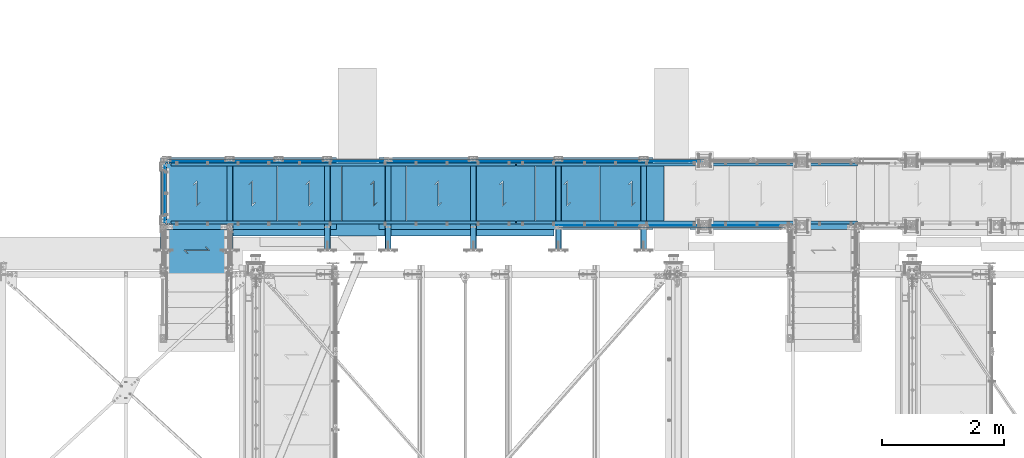
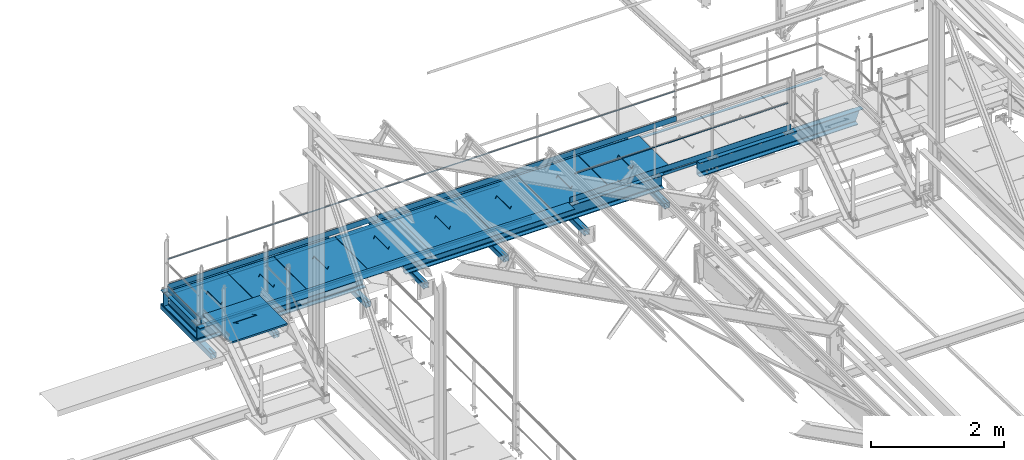
# One storey, part 52 of 496: 34 beams, 32 elements without a shape of their own.
"""IFC2X3 building model written with IfcOpenShell, lengths in millimetres."""

from ifc_helpers import new_model, si_unit, frame, origin_with_axes, origin_2d_with_axis, place, context, subcontext, project, spatial, polyline, rectangle, hollow_rectangle, hollow_circle, l_section, u_section, outline, extrude, boolean, clip, halfspace, material, type_object, element, aggregate, save


model = new_model("IFC2X3")

# Units and contexts
model_context = context("Model", 3, precision=1e-05, world=origin_with_axes())
body_context = subcontext(model_context, "Body", "Model", "MODEL_VIEW")
ifc_project = project(units=[si_unit("LENGTHUNIT", "METRE", prefix="MILLI"), si_unit("AREAUNIT", "SQUARE_METRE"), si_unit("VOLUMEUNIT", "CUBIC_METRE"), si_unit("MASSUNIT", "GRAM", prefix="KILO"), si_unit("TIMEUNIT", "SECOND"), si_unit("PLANEANGLEUNIT", "RADIAN"), si_unit("SOLIDANGLEUNIT", "STERADIAN"), si_unit("THERMODYNAMICTEMPERATUREUNIT", "DEGREE_CELSIUS"), si_unit("LUMINOUSINTENSITYUNIT", "LUMEN")], contexts=[model_context])

# Site, building, storey
site_placement = place(None, origin_with_axes())
site = spatial("IfcSite", under=ifc_project, at=site_placement, CompositionType="ELEMENT")
building_placement = place(site_placement, origin_with_axes())
building = spatial("IfcBuilding", under=site, at=building_placement, Name="Undefined", CompositionType="ELEMENT")
storey_placement = place(building_placement, origin_with_axes())
storey = spatial("IfcBuildingStorey", under=building, at=storey_placement, Name="Undefined", CompositionType="ELEMENT", Elevation=0.0)

# Assembly, beam
assembly_1_placement = place(storey_placement, origin_with_axes())
assembly_1 = element("IfcElementAssembly", 1, at=assembly_1_placement, inside=storey, Name="MAIN COURANTE", AssemblyPlace="NOTDEFINED", PredefinedType="NOTDEFINED")
ifc_material_1 = material(Name="Undefined/S235-E24")
beam_type_1 = type_object("IfcBeamType", PredefinedType="NOTDEFINED")
beam_1_placement = place(assembly_1_placement, frame((17579.9961849193, 15930.0010285632, 8703.00000001012), z_axis=(0.0, -1.0, 0.0), x_axis=(-1.0, 0.0, 0.0)))
beam_1 = element("IfcBeam", 2, at=beam_1_placement, type_object=beam_type_1, material=ifc_material_1, Name="VIDE", context=body_context, shape_type="SweptSolid", body=[
    extrude(rectangle(XDim=6.0, YDim=200.0, at=origin_2d_with_axis()), frame((5350.00080258181, 0.0, 0.0), z_axis=(-1.0, 0.0, 0.0), x_axis=(0.0, -1.0, 0.0)), (0.0, 0.0, 1.0), 5350.0),
])
aggregate(assembly_1, [beam_1])

assembly_2_placement = place(storey_placement, origin_with_axes())
assembly_2 = element("IfcElementAssembly", 3, at=assembly_2_placement, inside=storey, Name="MAIN COURANTE", AssemblyPlace="NOTDEFINED", PredefinedType="NOTDEFINED")
beam_type_2 = type_object("IfcBeamType", PredefinedType="NOTDEFINED")
beam_2_placement = place(assembly_2_placement, frame((17659.9961849193, 15969.9996218665, 9243.80000001012), z_axis=(0.0, -1.0, 0.0), x_axis=(1.0, 0.0, 0.0)))
beam_2 = element("IfcBeam", 4, at=beam_2_placement, type_object=beam_type_2, material=ifc_material_1, Name="LISSE", context=body_context, shape_type="SweptSolid", body=[
    extrude(hollow_circle(Radius=10.64999962, WallThickness=2.0, at=origin_2d_with_axis()), frame((3709.98893280412, 0.0, -4.91012946880298e-20), z_axis=(-1.0, 0.0, 0.0), x_axis=(0.0, -1.0, 0.0)), (0.0, 0.0, 1.0), 3709.99),
])
aggregate(assembly_2, [beam_2])

assembly_3_placement = place(storey_placement, origin_with_axes())
assembly_3 = element("IfcElementAssembly", 5, at=assembly_3_placement, inside=storey, Name="MAIN COURANTE", AssemblyPlace="NOTDEFINED", PredefinedType="NOTDEFINED")
beam_3_placement = place(assembly_3_placement, frame((14859.9961849193, 17089.994110687, 9243.80000001012), z_axis=(0.0, 1.0, 0.0), x_axis=(1.0, 0.0, 0.0)))
beam_3 = element("IfcBeam", 6, at=beam_3_placement, type_object=beam_type_2, material=ifc_material_1, Name="LISSE", context=body_context, shape_type="SweptSolid", body=[
    extrude(hollow_circle(Radius=10.64999962, WallThickness=2.0, at=origin_2d_with_axis()), frame((5189.99999999648, 0.0, 0.0), z_axis=(-1.0, 0.0, 0.0), x_axis=(0.0, -1.0, 0.0)), (0.0, 0.0, 1.0), 5190.0),
])

assembly_4_placement = place(storey_placement, origin_with_axes())
assembly_4 = element("IfcElementAssembly", 7, at=assembly_4_placement, inside=storey, Name="MAIN COURANTE", AssemblyPlace="NOTDEFINED", PredefinedType="NOTDEFINED")
beam_4_placement = place(assembly_4_placement, frame((11225.0062475613, 17089.9937511109, 9243.80000001012), z_axis=(0.0, 1.0, 0.0), x_axis=(1.0, 0.0, 0.0)))
beam_4 = element("IfcBeam", 8, at=beam_4_placement, type_object=beam_type_2, material=ifc_material_1, Name="LISSE", context=body_context, shape_type="SweptSolid", body=[
    extrude(hollow_circle(Radius=10.64999962, WallThickness=2.0, at=origin_2d_with_axis()), frame((3624.98993735802, 0.0, 0.0), z_axis=(-1.0, 0.0, 0.0), x_axis=(0.0, -1.0, 0.0)), (0.0, 0.0, 1.0), 3624.99),
])

assembly_5_placement = place(storey_placement, origin_with_axes())
assembly_5 = element("IfcElementAssembly", 9, at=assembly_5_placement, inside=storey, Name="CONSOLE", AssemblyPlace="NOTDEFINED", PredefinedType="NOTDEFINED")
beam_type_3 = type_object("IfcBeamType", PredefinedType="NOTDEFINED")
beam_5_placement = place(assembly_5_placement, frame((12255.0007605158, 17119.9934272352, 8390.0), z_axis=(-1.0, 0.0, 0.0), x_axis=(0.0, -1.0, 0.0)))
beam_5 = element("IfcBeam", 10, at=beam_5_placement, type_object=beam_type_3, material=ifc_material_1, Name="CONSOLE", context=body_context, shape_type="CSG", body=[
    boolean("DIFFERENCE", extrude(hollow_rectangle(XDim=100.0, YDim=100.0, WallThickness=5.0, InnerFilletRadius=5.0, OuterFilletRadius=10.0, at=origin_2d_with_axis()), frame((1517.99358081521, 0.0, 0.0), z_axis=(-1.0, 0.0, 0.0), x_axis=(0.0, -1.0, 0.0)), (0.0, 0.0, 1.0), 1517.99), extrude(outline(polyline([(0.0, 0.0), (20.0, 0.0), (20.0, 300.0), (0.0, 300.0), (-118.0, 275.0), (-118.0, 155.0), (0.0, 0.0)])), frame((1497.99342723521, -215.0, -4.0), z_axis=(0.0, 0.0, 1.0), x_axis=(1.0, 0.0, 0.0)), (0.0, 0.0, 1.0), 8.0)),
])
aggregate(assembly_5, [beam_5])

assembly_6_placement = place(storey_placement, origin_with_axes())
assembly_6 = element("IfcElementAssembly", 11, at=assembly_6_placement, inside=storey, Name="CONSOLE", AssemblyPlace="NOTDEFINED", PredefinedType="NOTDEFINED")
beam_6_placement = place(assembly_6_placement, frame((19055.0007605158, 17119.9934272352, 8390.0), z_axis=(-1.0, 0.0, 0.0), x_axis=(0.0, -1.0, 0.0)))
beam_6 = element("IfcBeam", 12, at=beam_6_placement, type_object=beam_type_3, material=ifc_material_1, Name="CONSOLE", context=body_context, shape_type="CSG", body=[
    boolean("DIFFERENCE", extrude(hollow_rectangle(XDim=100.0, YDim=100.0, WallThickness=5.0, InnerFilletRadius=5.0, OuterFilletRadius=10.0, at=origin_2d_with_axis()), frame((1517.99358081521, 0.0, 0.0), z_axis=(-1.0, 0.0, 0.0), x_axis=(0.0, -1.0, 0.0)), (0.0, 0.0, 1.0), 1517.99), extrude(outline(polyline([(0.0, 0.0), (20.0, 0.0), (20.0, 300.0), (0.0, 300.0), (-118.0, 275.0), (-118.0, 155.0), (0.0, 0.0)])), frame((1497.99342723521, -215.0, -4.0), z_axis=(0.0, 0.0, 1.0), x_axis=(1.0, 0.0, 0.0)), (0.0, 0.0, 1.0), 8.0)),
])
aggregate(assembly_6, [beam_6])

assembly_7_placement = place(storey_placement, origin_with_axes())
assembly_7 = element("IfcElementAssembly", 13, at=assembly_7_placement, inside=storey, Name="CONSOLE", AssemblyPlace="NOTDEFINED", PredefinedType="NOTDEFINED")
beam_7_placement = place(assembly_7_placement, frame((17655.0007605158, 17119.9934272352, 8390.0), z_axis=(-1.0, 0.0, 0.0), x_axis=(0.0, -1.0, 0.0)))
beam_7 = element("IfcBeam", 14, at=beam_7_placement, type_object=beam_type_3, material=ifc_material_1, Name="CONSOLE", context=body_context, shape_type="CSG", body=[
    boolean("DIFFERENCE", extrude(hollow_rectangle(XDim=100.0, YDim=100.0, WallThickness=5.0, InnerFilletRadius=5.0, OuterFilletRadius=10.0, at=origin_2d_with_axis()), frame((1517.99358081521, 0.0, 0.0), z_axis=(-1.0, 0.0, 0.0), x_axis=(0.0, -1.0, 0.0)), (0.0, 0.0, 1.0), 1517.99), extrude(outline(polyline([(0.0, 0.0), (20.0, 0.0), (20.0, 300.0), (0.0, 300.0), (-118.0, 275.0), (-118.0, 155.0), (0.0, 0.0)])), frame((1497.99342723521, -215.0, -4.0), z_axis=(0.0, 0.0, 1.0), x_axis=(1.0, 0.0, 0.0)), (0.0, 0.0, 1.0), 8.0)),
])
aggregate(assembly_7, [beam_7])

assembly_8_placement = place(storey_placement, origin_with_axes())
assembly_8 = element("IfcElementAssembly", 15, at=assembly_8_placement, inside=storey, Name="CONSOLE", AssemblyPlace="NOTDEFINED", PredefinedType="NOTDEFINED")
beam_8_placement = place(assembly_8_placement, frame((16255.0007605158, 17119.9934272352, 8390.0), z_axis=(-1.0, 0.0, 0.0), x_axis=(0.0, -1.0, 0.0)))
beam_8 = element("IfcBeam", 16, at=beam_8_placement, type_object=beam_type_3, material=ifc_material_1, Name="CONSOLE", context=body_context, shape_type="CSG", body=[
    boolean("DIFFERENCE", extrude(hollow_rectangle(XDim=100.0, YDim=100.0, WallThickness=5.0, InnerFilletRadius=5.0, OuterFilletRadius=10.0, at=origin_2d_with_axis()), frame((1517.99358081521, 0.0, 0.0), z_axis=(-1.0, 0.0, 0.0), x_axis=(0.0, -1.0, 0.0)), (0.0, 0.0, 1.0), 1517.99), extrude(outline(polyline([(0.0, 0.0), (20.0, 0.0), (20.0, 300.0), (0.0, 300.0), (-118.0, 275.0), (-118.0, 155.0), (0.0, 0.0)])), frame((1497.99342723521, -215.0, -4.0), z_axis=(0.0, 0.0, 1.0), x_axis=(1.0, 0.0, 0.0)), (0.0, 0.0, 1.0), 8.0)),
])
aggregate(assembly_8, [beam_8])

assembly_9_placement = place(storey_placement, origin_with_axes())
assembly_9 = element("IfcElementAssembly", 17, at=assembly_9_placement, inside=storey, Name="CONSOLE", AssemblyPlace="NOTDEFINED", PredefinedType="NOTDEFINED")
beam_9_placement = place(assembly_9_placement, frame((14855.0007605158, 17119.9934272352, 8390.0), z_axis=(-1.0, 0.0, 0.0), x_axis=(0.0, -1.0, 0.0)))
beam_9 = element("IfcBeam", 18, at=beam_9_placement, type_object=beam_type_3, material=ifc_material_1, Name="CONSOLE", context=body_context, shape_type="CSG", body=[
    boolean("DIFFERENCE", extrude(hollow_rectangle(XDim=100.0, YDim=100.0, WallThickness=5.0, InnerFilletRadius=5.0, OuterFilletRadius=10.0, at=origin_2d_with_axis()), frame((1517.99358081521, 0.0, 0.0), z_axis=(-1.0, 0.0, 0.0), x_axis=(0.0, -1.0, 0.0)), (0.0, 0.0, 1.0), 1517.99), extrude(outline(polyline([(0.0, 0.0), (20.0, 0.0), (20.0, 300.0), (0.0, 300.0), (-118.0, 275.0), (-118.0, 155.0), (0.0, 0.0)])), frame((1497.99342723521, -215.0, -4.0), z_axis=(0.0, 0.0, 1.0), x_axis=(1.0, 0.0, 0.0)), (0.0, 0.0, 1.0), 8.0)),
])
aggregate(assembly_9, [beam_9])

assembly_10_placement = place(storey_placement, origin_with_axes())
assembly_10 = element("IfcElementAssembly", 19, at=assembly_10_placement, inside=storey, Name="CONSOLE", AssemblyPlace="NOTDEFINED", PredefinedType="NOTDEFINED")
beam_10_placement = place(assembly_10_placement, frame((13855.0007605158, 17119.9934272352, 8390.0), z_axis=(-1.0, 0.0, 0.0), x_axis=(0.0, -1.0, 0.0)))
beam_10 = element("IfcBeam", 20, at=beam_10_placement, type_object=beam_type_3, material=ifc_material_1, Name="CONSOLE", context=body_context, shape_type="CSG", body=[
    boolean("DIFFERENCE", extrude(hollow_rectangle(XDim=100.0, YDim=100.0, WallThickness=5.0, InnerFilletRadius=5.0, OuterFilletRadius=10.0, at=origin_2d_with_axis()), frame((1517.99358081521, 0.0, 0.0), z_axis=(-1.0, 0.0, 0.0), x_axis=(0.0, -1.0, 0.0)), (0.0, 0.0, 1.0), 1517.99), extrude(outline(polyline([(0.0, 0.0), (20.0, 0.0), (20.0, 300.0), (0.0, 300.0), (-118.0, 275.0), (-118.0, 155.0), (0.0, 0.0)])), frame((1497.99342723521, -215.0, -4.0), z_axis=(0.0, 0.0, 1.0), x_axis=(1.0, 0.0, 0.0)), (0.0, 0.0, 1.0), 8.0)),
])
aggregate(assembly_10, [beam_10])

assembly_11_placement = place(storey_placement, origin_with_axes())
assembly_11 = element("IfcElementAssembly", 21, at=assembly_11_placement, inside=storey, Name="CONSOLE", AssemblyPlace="NOTDEFINED", PredefinedType="NOTDEFINED")
beam_11_placement = place(assembly_11_placement, frame((11165.0007605157, 17119.9935808152, 8390.0), z_axis=(-1.0, 0.0, 0.0), x_axis=(0.0, -1.0, 0.0)))
beam_11 = element("IfcBeam", 22, at=beam_11_placement, type_object=beam_type_3, material=ifc_material_1, Name="CONSOLE", context=body_context, shape_type="CSG", body=[
    boolean("DIFFERENCE", extrude(hollow_rectangle(XDim=100.0, YDim=100.0, WallThickness=5.0, InnerFilletRadius=5.0, OuterFilletRadius=10.0, at=origin_2d_with_axis()), frame((1517.99358081521, 0.0, 0.0), z_axis=(-1.0, 0.0, 0.0), x_axis=(0.0, -1.0, 0.0)), (0.0, 0.0, 1.0), 1517.99), extrude(outline(polyline([(0.0, 0.0), (20.0, 0.0), (20.0, 300.0), (0.0, 300.0), (-118.0, 275.0), (-118.0, 155.0), (0.0, 0.0)])), frame((1497.99358081521, -215.0, -4.0), z_axis=(0.0, 0.0, 1.0), x_axis=(1.0, 0.0, 0.0)), (0.0, 0.0, 1.0), 8.0)),
])
aggregate(assembly_11, [beam_11])

assembly_12_placement = place(storey_placement, origin_with_axes())
assembly_12 = element("IfcElementAssembly", 23, at=assembly_12_placement, inside=storey, AssemblyPlace="NOTDEFINED", PredefinedType="NOTDEFINED")
beam_type_4 = type_object("IfcBeamType", PredefinedType="NOTDEFINED")
beam_12_placement = place(assembly_12_placement, frame((21439.9851177268, 16002.5124739778, 8760.00000001012), z_axis=(0.0, 0.0, -1.0), x_axis=(-1.0, 0.0, 0.0)))
beam_12 = element("IfcBeam", 24, at=beam_12_placement, type_object=beam_type_4, material=ifc_material_1, context=body_context, shape_type="SweptSolid", body=[
    extrude(rectangle(XDim=5.0, YDim=100.0, at=origin_2d_with_axis()), frame((3849.98893280756, 0.0, 0.0), z_axis=(-1.0, 0.0, 0.0), x_axis=(0.0, -1.0, 0.0)), (0.0, 0.0, 1.0), 3849.99),
])
aggregate(assembly_12, [beam_12])

# Beam
beam_13_placement = place(assembly_3_placement, frame((20054.9961849193, 17057.481480291, 8760.00000001012), z_axis=(0.0, 0.0, -1.0), x_axis=(-1.0, 0.0, 0.0)))
beam_13 = element("IfcBeam", 25, at=beam_13_placement, type_object=beam_type_4, material=ifc_material_1, context=body_context, shape_type="SweptSolid", body=[
    extrude(rectangle(XDim=5.0, YDim=100.0, at=origin_2d_with_axis()), frame((5200.0, 0.0, 0.0), z_axis=(-1.0, 0.0, 0.0), x_axis=(0.0, -1.0, 0.0)), (0.0, 0.0, 1.0), 5200.0),
])

aggregate(assembly_3, [beam_13, beam_3])

beam_14_placement = place(assembly_4_placement, frame((14854.9961849193, 17057.481480291, 8760.00000001012), z_axis=(0.0, 0.0, -1.0), x_axis=(-1.0, 0.0, 0.0)))
beam_14 = element("IfcBeam", 26, at=beam_14_placement, type_object=beam_type_4, material=ifc_material_1, context=body_context, shape_type="SweptSolid", body=[
    extrude(rectangle(XDim=5.0, YDim=100.0, at=origin_2d_with_axis()), frame((3649.98401228106, 0.0, 0.0), z_axis=(-1.0, 0.0, 0.0), x_axis=(0.0, -1.0, 0.0)), (0.0, 0.0, 1.0), 3649.98),
])

aggregate(assembly_4, [beam_14, beam_4])

# Assembly, beam
assembly_13_placement = place(storey_placement, origin_with_axes())
assembly_13 = element("IfcElementAssembly", 27, at=assembly_13_placement, inside=storey, Name="MAIN COURANTE", AssemblyPlace="NOTDEFINED", PredefinedType="NOTDEFINED")
beam_15_placement = place(assembly_13_placement, frame((11182.4987221813, 17034.9977309424, 8760.00000001012), z_axis=(0.0, 0.0, -1.0), x_axis=(0.0, -1.0, 0.0)))
beam_15 = element("IfcBeam", 28, at=beam_15_placement, type_object=beam_type_4, material=ifc_material_1, context=body_context, shape_type="SweptSolid", body=[
    extrude(rectangle(XDim=5.0, YDim=100.0, at=origin_2d_with_axis()), frame((1009.99407492107, 0.0, 0.0), z_axis=(-1.0, 0.0, 0.0), x_axis=(0.0, -1.0, 0.0)), (0.0, 0.0, 1.0), 1009.99),
])
aggregate(assembly_13, [beam_15])

assembly_14_placement = place(storey_placement, origin_with_axes())
assembly_14 = element("IfcElementAssembly", 29, at=assembly_14_placement, inside=storey, Name="PALIER", AssemblyPlace="NOTDEFINED", PredefinedType="NOTDEFINED")
beam_type_5 = type_object("IfcBeamType", PredefinedType="NOTDEFINED")
beam_16_placement = place(assembly_14_placement, frame((13024.9999902344, 16530.001494552, 8685.0), z_axis=(0.0, 1.0, 0.0), x_axis=(-1.0, 0.0, 0.0)))
beam_16 = element("IfcBeam", 30, at=beam_16_placement, type_object=beam_type_5, material=ifc_material_1, Name="PALIER", context=body_context, shape_type="CSG", body=[
    boolean("DIFFERENCE", extrude(rectangle(XDim=30.0, YDim=990.0, at=origin_2d_with_axis()), frame((810.0, 0.0, 0.0), z_axis=(-1.0, 0.0, 0.0), x_axis=(0.0, -1.0, 0.0)), (0.0, 0.0, 1.0), 810.0), extrude(outline(polyline([(0.0, 0.0), (87.0678024292865, -7.27595761418343e-12), (-195.774902343946, 282.842712402629), (-132.842712402475, 282.842712402631), (-132.842712402482, 292.84271240264), (-219.917037964085, 292.84271240264), (62.9256706238448, 10.0000000000091), (-1.81898940354586e-10, 10.0000000000073), (0.0, 0.0)])), frame((348.432567747415, 17.4998126435639, -150.504333634472), z_axis=(0.0, -1.0, 0.0), x_axis=(0.707106781186548, 0.0, -0.707106781186548)), (0.0, 0.0, 1.0), 35.0)),
])
aggregate(assembly_14, [beam_16])

assembly_15_placement = place(storey_placement, origin_with_axes())
assembly_15 = element("IfcElementAssembly", 31, at=assembly_15_placement, inside=storey, Name="PALIER", AssemblyPlace="NOTDEFINED", PredefinedType="NOTDEFINED")
beam_17_placement = place(assembly_15_placement, frame((14084.9999902344, 16530.001494552, 8685.0), z_axis=(0.0, 1.0, 0.0), x_axis=(-1.0, 0.0, 0.0)))
beam_17 = element("IfcBeam", 32, at=beam_17_placement, type_object=beam_type_5, material=ifc_material_1, Name="PALIER", context=body_context, shape_type="CSG", body=[
    boolean("DIFFERENCE", extrude(rectangle(XDim=30.0, YDim=990.0, at=origin_2d_with_axis()), frame((1050.0, 0.0, 0.0), z_axis=(-1.0, 0.0, 0.0), x_axis=(0.0, -1.0, 0.0)), (0.0, 0.0, 1.0), 1050.0), extrude(outline(polyline([(0.0, 0.0), (87.0678024292865, -7.27595761418343e-12), (-195.774902343946, 282.842712402629), (-132.842712402475, 282.842712402631), (-132.842712402482, 292.84271240264), (-219.917037964085, 292.84271240264), (62.9256706238448, 10.0000000000091), (-1.81898940354586e-10, 10.0000000000073), (0.0, 0.0)])), frame((468.433762432338, 17.4998126435639, -150.504333634472), z_axis=(0.0, -1.0, 0.0), x_axis=(0.707106781186548, 0.0, -0.707106781186548)), (0.0, 0.0, 1.0), 35.0)),
])
aggregate(assembly_15, [beam_17])

assembly_16_placement = place(storey_placement, origin_with_axes())
assembly_16 = element("IfcElementAssembly", 33, at=assembly_16_placement, inside=storey, Name="PALIER", AssemblyPlace="NOTDEFINED", PredefinedType="NOTDEFINED")
beam_18_placement = place(assembly_16_placement, frame((15144.9999902344, 16530.001494552, 8685.0), z_axis=(0.0, 1.0, 0.0), x_axis=(-1.0, 0.0, 0.0)))
beam_18 = element("IfcBeam", 34, at=beam_18_placement, type_object=beam_type_5, material=ifc_material_1, Name="PALIER", context=body_context, shape_type="CSG", body=[
    boolean("DIFFERENCE", extrude(rectangle(XDim=30.0, YDim=990.0, at=origin_2d_with_axis()), frame((1050.0, 0.0, 0.0), z_axis=(-1.0, 0.0, 0.0), x_axis=(0.0, -1.0, 0.0)), (0.0, 0.0, 1.0), 1050.0), extrude(outline(polyline([(0.0, 0.0), (87.0678024292865, -7.27595761418343e-12), (-195.774902343946, 282.842712402629), (-132.842712402475, 282.842712402631), (-132.842712402482, 292.84271240264), (-219.917037964085, 292.84271240264), (62.9256706238448, 10.0000000000091), (-1.81898940354586e-10, 10.0000000000073), (0.0, 0.0)])), frame((468.433762432338, 17.4998126435639, -150.504333634472), z_axis=(0.0, -1.0, 0.0), x_axis=(0.707106781186548, 0.0, -0.707106781186548)), (0.0, 0.0, 1.0), 35.0)),
])
aggregate(assembly_16, [beam_18])

assembly_17_placement = place(storey_placement, origin_with_axes())
assembly_17 = element("IfcElementAssembly", 35, at=assembly_17_placement, inside=storey, Name="PALIER", AssemblyPlace="NOTDEFINED", PredefinedType="NOTDEFINED")
beam_19_placement = place(assembly_17_placement, frame((16204.9999902344, 16530.001494552, 8685.0), z_axis=(0.0, 1.0, 0.0), x_axis=(-1.0, 0.0, 0.0)))
beam_19 = element("IfcBeam", 36, at=beam_19_placement, type_object=beam_type_5, material=ifc_material_1, Name="PALIER", context=body_context, shape_type="CSG", body=[
    boolean("DIFFERENCE", extrude(rectangle(XDim=30.0, YDim=990.0, at=origin_2d_with_axis()), frame((1050.0, 0.0, 0.0), z_axis=(-1.0, 0.0, 0.0), x_axis=(0.0, -1.0, 0.0)), (0.0, 0.0, 1.0), 1050.0), extrude(outline(polyline([(0.0, 0.0), (87.0678024292865, -7.27595761418343e-12), (-195.774902343946, 282.842712402629), (-132.842712402475, 282.842712402631), (-132.842712402482, 292.84271240264), (-219.917037964085, 292.84271240264), (62.9256706238448, 10.0000000000091), (-1.81898940354586e-10, 10.0000000000073), (0.0, 0.0)])), frame((468.433762432338, 17.4998126435639, -150.504333634472), z_axis=(0.0, -1.0, 0.0), x_axis=(0.707106781186548, 0.0, -0.707106781186548)), (0.0, 0.0, 1.0), 35.0)),
])
aggregate(assembly_17, [beam_19])

assembly_18_placement = place(storey_placement, origin_with_axes())
assembly_18 = element("IfcElementAssembly", 37, at=assembly_18_placement, inside=storey, Name="PALIER", AssemblyPlace="NOTDEFINED", PredefinedType="NOTDEFINED")
beam_20_placement = place(assembly_18_placement, frame((17264.9999902344, 16530.001494552, 8685.0), z_axis=(0.0, 1.0, 0.0), x_axis=(-1.0, 0.0, 0.0)))
beam_20 = element("IfcBeam", 38, at=beam_20_placement, type_object=beam_type_5, material=ifc_material_1, Name="PALIER", context=body_context, shape_type="CSG", body=[
    boolean("DIFFERENCE", extrude(rectangle(XDim=30.0, YDim=990.0, at=origin_2d_with_axis()), frame((1050.0, 0.0, 0.0), z_axis=(-1.0, 0.0, 0.0), x_axis=(0.0, -1.0, 0.0)), (0.0, 0.0, 1.0), 1050.0), extrude(outline(polyline([(0.0, 0.0), (87.0678024292865, -7.27595761418343e-12), (-195.774902343946, 282.842712402629), (-132.842712402475, 282.842712402631), (-132.842712402482, 292.84271240264), (-219.917037964085, 292.84271240264), (62.9256706238448, 10.0000000000091), (-1.81898940354586e-10, 10.0000000000073), (0.0, 0.0)])), frame((468.432567747415, 17.4998126435639, -150.504333634472), z_axis=(0.0, -1.0, 0.0), x_axis=(0.707106781186548, 0.0, -0.707106781186548)), (0.0, 0.0, 1.0), 35.0)),
])
aggregate(assembly_18, [beam_20])

assembly_19_placement = place(storey_placement, origin_with_axes())
assembly_19 = element("IfcElementAssembly", 39, at=assembly_19_placement, inside=storey, Name="PALIER", AssemblyPlace="NOTDEFINED", PredefinedType="NOTDEFINED")
beam_21_placement = place(assembly_19_placement, frame((18324.9999902344, 16530.001494552, 8685.0), z_axis=(0.0, 1.0, 0.0), x_axis=(-1.0, 0.0, 0.0)))
beam_21 = element("IfcBeam", 40, at=beam_21_placement, type_object=beam_type_5, material=ifc_material_1, Name="PALIER", context=body_context, shape_type="CSG", body=[
    boolean("DIFFERENCE", extrude(rectangle(XDim=30.0, YDim=990.0, at=origin_2d_with_axis()), frame((1050.0, 0.0, 0.0), z_axis=(-1.0, 0.0, 0.0), x_axis=(0.0, -1.0, 0.0)), (0.0, 0.0, 1.0), 1050.0), extrude(outline(polyline([(0.0, 0.0), (87.0678024292865, -7.27595761418343e-12), (-195.774902343946, 282.842712402629), (-132.842712402475, 282.842712402631), (-132.842712402482, 292.84271240264), (-219.917037964085, 292.84271240264), (62.9256706238448, 10.0000000000091), (-1.81898940354586e-10, 10.0000000000073), (0.0, 0.0)])), frame((468.433762432338, 17.4998126435639, -150.504333634472), z_axis=(0.0, -1.0, 0.0), x_axis=(0.707106781186548, 0.0, -0.707106781186548)), (0.0, 0.0, 1.0), 35.0)),
])
aggregate(assembly_19, [beam_21])

assembly_20_placement = place(storey_placement, origin_with_axes())
assembly_20 = element("IfcElementAssembly", 41, at=assembly_20_placement, inside=storey, Name="PALIER", AssemblyPlace="NOTDEFINED", PredefinedType="NOTDEFINED")
beam_22_placement = place(assembly_20_placement, frame((19384.9999902344, 16530.001494552, 8685.0), z_axis=(0.0, 1.0, 0.0), x_axis=(-1.0, 0.0, 0.0)))
beam_22 = element("IfcBeam", 42, at=beam_22_placement, type_object=beam_type_5, material=ifc_material_1, Name="PALIER", context=body_context, shape_type="CSG", body=[
    boolean("DIFFERENCE", extrude(rectangle(XDim=30.0, YDim=990.0, at=origin_2d_with_axis()), frame((1050.0, 0.0, 0.0), z_axis=(-1.0, 0.0, 0.0), x_axis=(0.0, -1.0, 0.0)), (0.0, 0.0, 1.0), 1050.0), extrude(outline(polyline([(0.0, 0.0), (87.0678024292865, -7.27595761418343e-12), (-195.774902343946, 282.842712402629), (-132.842712402475, 282.842712402631), (-132.842712402482, 292.84271240264), (-219.917037964085, 292.84271240264), (62.9256706238448, 10.0000000000091), (-1.81898940354586e-10, 10.0000000000073), (0.0, 0.0)])), frame((468.433762432338, 17.4998126435639, -150.504333634472), z_axis=(0.0, -1.0, 0.0), x_axis=(0.707106781186548, 0.0, -0.707106781186548)), (0.0, 0.0, 1.0), 35.0)),
])
aggregate(assembly_20, [beam_22])

assembly_21_placement = place(storey_placement, origin_with_axes())
assembly_21 = element("IfcElementAssembly", 43, at=assembly_21_placement, inside=storey, Name="PALIER", AssemblyPlace="NOTDEFINED", PredefinedType="NOTDEFINED")
beam_23_placement = place(assembly_21_placement, frame((11709.9938089558, 16020.0002777729, 8865.0), z_axis=(-1.0, 0.0, 0.0), x_axis=(0.0, -1.0, 0.0)))
beam_23 = element("IfcBeam", 44, at=beam_23_placement, type_object=beam_type_5, material=ifc_material_1, Name="PALIER", context=body_context, shape_type="CSG", body=[
    boolean("DIFFERENCE", extrude(rectangle(XDim=30.0, YDim=990.0, at=origin_2d_with_axis()), frame((845.000486722794, 0.0, 0.0), z_axis=(-1.0, 0.0, 0.0), x_axis=(0.0, -1.0, 0.0)), (0.0, 0.0, 1.0), 845.0), extrude(outline(polyline([(0.0, 0.0), (87.0678024292865, -7.27595761418343e-12), (-195.774902343946, 282.842712402629), (-132.842712402475, 282.842712402631), (-132.842712402482, 292.84271240264), (-219.917037964085, 292.84271240264), (62.9256706238448, 10.0000000000091), (-1.81898940354586e-10, 10.0000000000073), (0.0, 0.0)])), frame((365.937115922121, 17.4998126435639, -150.509457285396), z_axis=(0.0, -1.0, 0.0), x_axis=(0.707106781186548, 0.0, -0.707106781186548)), (0.0, 0.0, 1.0), 35.0)),
])
aggregate(assembly_21, [beam_23])

assembly_22_placement = place(storey_placement, origin_with_axes())
assembly_22 = element("IfcElementAssembly", 45, at=assembly_22_placement, inside=storey, Name="PALIER", AssemblyPlace="NOTDEFINED", PredefinedType="NOTDEFINED")
beam_24_placement = place(assembly_22_placement, frame((12204.9999902344, 16529.9996474981, 8685.0), z_axis=(0.0, 1.0, 0.0), x_axis=(-1.0, 0.0, 0.0)))
beam_24 = element("IfcBeam", 46, at=beam_24_placement, type_object=beam_type_5, material=ifc_material_1, Name="PALIER", context=body_context, shape_type="CSG", body=[
    boolean("DIFFERENCE", extrude(rectangle(XDim=30.0, YDim=990.0, at=origin_2d_with_axis()), frame((990.0, 0.0, 0.0), z_axis=(-1.0, 0.0, 0.0), x_axis=(0.0, -1.0, 0.0)), (0.0, 0.0, 1.0), 990.0), extrude(outline(polyline([(0.0, 0.0), (87.0678024292865, -7.27595761418343e-12), (-195.774902343946, 282.842712402629), (-132.842712402475, 282.842712402631), (-132.842712402482, 292.84271240264), (-219.917037964085, 292.84271240264), (62.9256706238448, 10.0000000000091), (-1.81898940354586e-10, 10.0000000000073), (0.0, 0.0)])), frame((438.43376243234, 17.4998126435639, -150.502486580543), z_axis=(0.0, -1.0, 0.0), x_axis=(0.707106781186548, 0.0, -0.707106781186548)), (0.0, 0.0, 1.0), 35.0)),
])
aggregate(assembly_22, [beam_24])

assembly_23_placement = place(storey_placement, origin_with_axes())
assembly_23 = element("IfcElementAssembly", 47, at=assembly_23_placement, inside=storey, Name="SUPPORT", AssemblyPlace="NOTDEFINED", PredefinedType="NOTDEFINED")
beam_type_6 = type_object("IfcBeamType", PredefinedType="NOTDEFINED")
beam_25_placement = place(assembly_23_placement, frame((11284.9999772195, 17005.0001222981, 8645.0), z_axis=(0.0, -1.0, 0.0), x_axis=(1.0, 0.0, 0.0)))
beam_25 = element("IfcBeam", 48, at=beam_25_placement, type_object=beam_type_6, material=ifc_material_1, Name="SUPPORT", context=body_context, shape_type="SweptSolid", body=[
    extrude(l_section(Depth=50.0, Width=50.0, Thickness=5.0, FilletRadius=7.0, EdgeRadius=3.5, at=origin_2d_with_axis()), frame((5660.00147115087, 0.0, 5.99275965946575e-19), z_axis=(-1.0, 0.0, 0.0), x_axis=(0.0, -1.0, 0.0)), (0.0, 0.0, 1.0), 5660.0),
])
aggregate(assembly_23, [beam_25])

assembly_24_placement = place(storey_placement, origin_with_axes())
assembly_24 = element("IfcElementAssembly", 49, at=assembly_24_placement, inside=storey, Name="SUPPORT", AssemblyPlace="NOTDEFINED", PredefinedType="NOTDEFINED")
beam_26_placement = place(assembly_24_placement, frame((16965.0018572728, 17004.9971808302, 8645.0), z_axis=(0.0, -1.0, 0.0), x_axis=(1.0, 0.0, 0.0)))
beam_26 = element("IfcBeam", 50, at=beam_26_placement, type_object=beam_type_6, material=ifc_material_1, Name="SUPPORT", context=body_context, shape_type="SweptSolid", body=[
    extrude(l_section(Depth=50.0, Width=50.0, Thickness=5.0, FilletRadius=7.0, EdgeRadius=3.5, at=origin_2d_with_axis()), frame((5599.99811694225, -1.81898940354586e-12, 0.0), z_axis=(-1.0, 0.0, 0.0), x_axis=(0.0, -1.0, 0.0)), (0.0, 0.0, 1.0), 5600.0),
])
aggregate(assembly_24, [beam_26])

assembly_25_placement = place(storey_placement, origin_with_axes())
assembly_25 = element("IfcElementAssembly", 51, at=assembly_25_placement, inside=storey, Name="SUPPORT", AssemblyPlace="NOTDEFINED", PredefinedType="NOTDEFINED")
beam_27_placement = place(assembly_25_placement, frame((16945.001448368, 16055.0028209027, 8645.0), z_axis=(0.0, 1.0, 0.0), x_axis=(-1.0, 0.0, 0.0)))
beam_27 = element("IfcBeam", 52, at=beam_27_placement, type_object=beam_type_6, material=ifc_material_1, Name="SUPPORT", context=body_context, shape_type="SweptSolid", body=[
    extrude(l_section(Depth=50.0, Width=50.0, Thickness=5.0, FilletRadius=7.0, EdgeRadius=3.5, at=origin_2d_with_axis()), frame((5660.00147115087, 0.0, 5.99275965946575e-19), z_axis=(-1.0, 0.0, 0.0), x_axis=(0.0, -1.0, 0.0)), (0.0, 0.0, 1.0), 5660.0),
])
aggregate(assembly_25, [beam_27])

assembly_26_placement = place(storey_placement, origin_with_axes())
assembly_26 = element("IfcElementAssembly", 53, at=assembly_26_placement, inside=storey, Name="SUPPORT", AssemblyPlace="NOTDEFINED", PredefinedType="NOTDEFINED")
beam_28_placement = place(assembly_26_placement, frame((22564.9999742115, 16055.0064199686, 8645.0), z_axis=(0.0, 1.0, 0.0), x_axis=(-1.0, 0.0, 0.0)))
beam_28 = element("IfcBeam", 54, at=beam_28_placement, type_object=beam_type_6, material=ifc_material_1, Name="SUPPORT", context=body_context, shape_type="SweptSolid", body=[
    extrude(l_section(Depth=50.0, Width=50.0, Thickness=5.0, FilletRadius=7.0, EdgeRadius=3.5, at=origin_2d_with_axis()), frame((5599.99811694225, -1.81898940354586e-12, 0.0), z_axis=(-1.0, 0.0, 0.0), x_axis=(0.0, -1.0, 0.0)), (0.0, 0.0, 1.0), 5600.0),
])
aggregate(assembly_26, [beam_28])

assembly_27_placement = place(storey_placement, origin_with_axes())
assembly_27 = element("IfcElementAssembly", 55, at=assembly_27_placement, inside=storey, AssemblyPlace="NOTDEFINED", PredefinedType="NOTDEFINED")
ifc_material_2 = material(Name="Undefined/S275-E28")
beam_type_7 = type_object("IfcBeamType", Name="UPN260", PredefinedType="NOTDEFINED")
beam_29_placement = place(assembly_27_placement, frame((19204.9983552809, 15984.998934546, 8570.00040284568), z_axis=(0.0, 0.0, -1.0), x_axis=(-1.0, 0.0, 0.0)))
beam_29 = element("IfcBeam", 56, at=beam_29_placement, type_object=beam_type_7, material=ifc_material_2, ObjectType="UPN260", context=body_context, shape_type="SweptSolid", body=[
    extrude(u_section(Depth=260.0, FlangeWidth=90.0, WebThickness=10.0, FlangeThickness=14.0, FilletRadius=14.0, EdgeRadius=7.0, FlangeSlope=0.0798299857122373, at=origin_2d_with_axis()), frame((4499.99759255654, -3.12035881680841e-20, 0.0), z_axis=(-1.0, 0.0, 0.0), x_axis=(0.0, -1.0, 0.0)), (0.0, 0.0, 1.0), 4500.0),
])
aggregate(assembly_27, [beam_29])

assembly_28_placement = place(storey_placement, origin_with_axes())
assembly_28 = element("IfcElementAssembly", 57, at=assembly_28_placement, inside=storey, AssemblyPlace="NOTDEFINED", PredefinedType="NOTDEFINED")
beam_30_placement = place(assembly_28_placement, frame((14705.0023015842, 17074.9935807951, 8570.00000000277), z_axis=(0.0, 0.0, -1.0), x_axis=(0.999999999997803, 2.09200000135276e-06, 1.31999999817392e-07)))
beam_30 = element("IfcBeam", 58, at=beam_30_placement, type_object=beam_type_7, material=ifc_material_2, ObjectType="UPN260", context=body_context, shape_type="SweptSolid", body=[
    extrude(u_section(Depth=260.0, FlangeWidth=90.0, WebThickness=10.0, FlangeThickness=14.0, FilletRadius=14.0, EdgeRadius=7.0, FlangeSlope=0.0798299857122373, at=origin_2d_with_axis()), frame((4499.99600895614, 5.18446821257041e-20, 1.19113902565585e-19), z_axis=(-1.0, 0.0, 0.0), x_axis=(0.0, -1.0, 0.0)), (0.0, 0.0, 1.0), 4500.0),
])
aggregate(assembly_28, [beam_30])

assembly_29_placement = place(storey_placement, origin_with_axes())
assembly_29 = element("IfcElementAssembly", 59, at=assembly_29_placement, inside=storey, AssemblyPlace="NOTDEFINED", PredefinedType="NOTDEFINED")
beam_31_placement = place(assembly_29_placement, frame((11165.0061849202, 16035.0001582241, 8570.0), z_axis=(0.0, 0.0, -1.0), x_axis=(-6.26399999950979e-06, 0.999999999980381, -3.63797880701241e-15)))
beam_31 = element("IfcBeam", 60, at=beam_31_placement, type_object=beam_type_7, material=ifc_material_2, ObjectType="UPN260", context=body_context, shape_type="SweptSolid", body=[
    extrude(u_section(Depth=260.0, FlangeWidth=90.0, WebThickness=10.0, FlangeThickness=14.0, FilletRadius=14.0, EdgeRadius=7.0, FlangeSlope=0.0798299857122373, at=origin_2d_with_axis()), frame((989.993334906396, 8.38556972227878e-19, 1.81898940354586e-12), z_axis=(-1.0, 0.0, 0.0), x_axis=(0.0, -1.0, 0.0)), (0.0, 0.0, 1.0), 989.99),
])
aggregate(assembly_29, [beam_31])

assembly_30_placement = place(storey_placement, origin_with_axes())
assembly_30 = element("IfcElementAssembly", 61, at=assembly_30_placement, inside=storey, AssemblyPlace="NOTDEFINED", PredefinedType="NOTDEFINED")
beam_32_placement = place(assembly_30_placement, frame((14004.9999949242, 15984.9990101991, 8570.00040284569), z_axis=(0.0, 0.0, -1.0), x_axis=(-1.0, 0.0, 0.0)))
beam_32 = element("IfcBeam", 62, at=beam_32_placement, type_object=beam_type_7, material=ifc_material_2, ObjectType="UPN260", context=body_context, shape_type="SweptSolid", body=[
    extrude(u_section(Depth=260.0, FlangeWidth=90.0, WebThickness=10.0, FlangeThickness=14.0, FilletRadius=14.0, EdgeRadius=7.0, FlangeSlope=0.0798299857122373, at=origin_2d_with_axis()), frame((2890.00922979254, 7.81791676837361e-20, 0.0), z_axis=(-1.0, 0.0, 0.0), x_axis=(0.0, -1.0, 0.0)), (0.0, 0.0, 1.0), 2890.01),
])
aggregate(assembly_30, [beam_32])

assembly_31_placement = place(storey_placement, origin_with_axes())
assembly_31 = element("IfcElementAssembly", 63, at=assembly_31_placement, inside=storey, AssemblyPlace="NOTDEFINED", PredefinedType="NOTDEFINED")
beam_33_placement = place(assembly_31_placement, frame((22666.0066060773, 15985.0038129365, 8570.00016502355), z_axis=(0.0, 0.0, -1.0), x_axis=(-0.99999999999782, -2.08799998896818e-06, 0.0)))
beam_33 = element("IfcBeam", 64, at=beam_33_placement, type_object=beam_type_7, material=ifc_material_2, ObjectType="UPN260", context=body_context, shape_type="Clipping", body=[
    clip(extrude(u_section(Depth=260.0, FlangeWidth=90.0, WebThickness=10.0, FlangeThickness=14.0, FilletRadius=14.0, EdgeRadius=7.0, FlangeSlope=0.0798299857122373, at=origin_2d_with_axis()), frame((2851.00654621966, 1.81898875317621e-12, -1.81898940354586e-12), z_axis=(-1.0, 0.0, 0.0), x_axis=(0.0, -1.0, 0.0)), (0.0, 0.0, 1.0), 2851.47), halfspace(frame((-0.00137994419492316, 1044.9963096463, -129.999999572165), z_axis=(-0.941670806890858, -1.29950571494012e-06, 0.336535423763727), x_axis=(0.336535062943427, 3.82000061089062e-07, 0.941670935841984)), False)),
])
aggregate(assembly_31, [beam_33])

assembly_32_placement = place(storey_placement, origin_with_axes())
assembly_32 = element("IfcElementAssembly", 65, at=assembly_32_placement, inside=storey, AssemblyPlace="NOTDEFINED", PredefinedType="NOTDEFINED")
beam_34_placement = place(assembly_32_placement, frame((11114.9922766982, 17074.9935807948, 8570.00000000277), z_axis=(0.0, 0.0, -1.0), x_axis=(0.999999999997803, 2.09200000135276e-06, 1.31999999817392e-07)))
beam_34 = element("IfcBeam", 66, at=beam_34_placement, type_object=beam_type_7, material=ifc_material_2, ObjectType="UPN260", context=body_context, shape_type="SweptSolid", body=[
    extrude(u_section(Depth=260.0, FlangeWidth=90.0, WebThickness=10.0, FlangeThickness=14.0, FilletRadius=14.0, EdgeRadius=7.0, FlangeSlope=0.0798299857122373, at=origin_2d_with_axis()), frame((2890.00764618388, 2.7468346268885e-19, 1.81898955654159e-12), z_axis=(-1.0, 0.0, 0.0), x_axis=(0.0, -1.0, 0.0)), (0.0, 0.0, 1.0), 2890.01),
])
aggregate(assembly_32, [beam_34])

save(model, "model.ifc")
